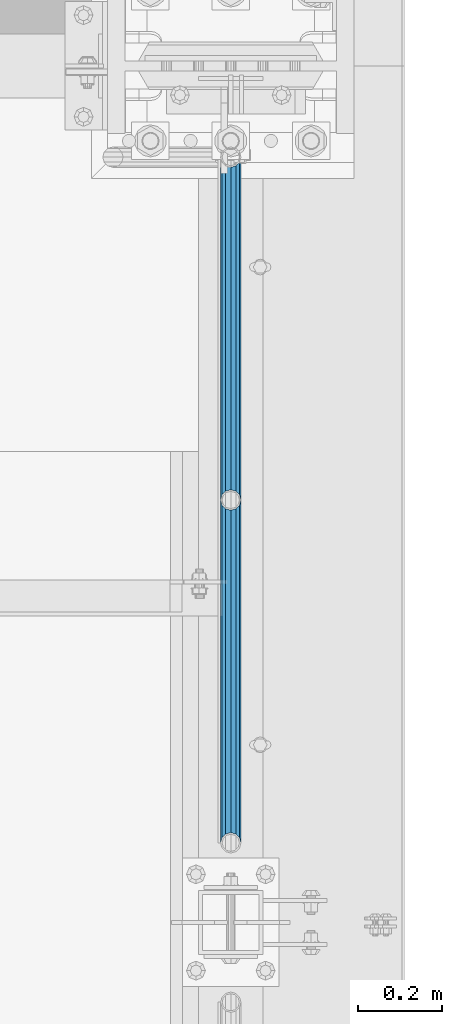
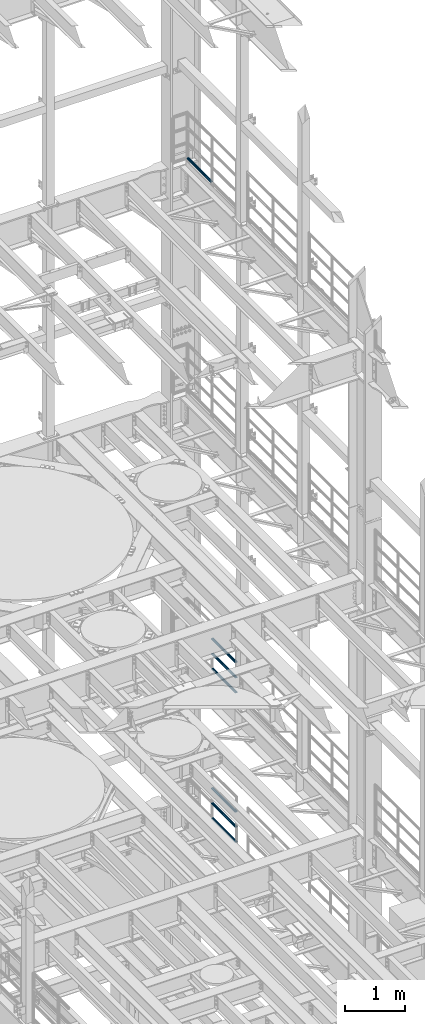
# One storey, part 1350 of 1876: 7 beams, 3 elements without a shape of their own.
"""IFC2X3 building model written with IfcOpenShell, lengths in millimetres."""

from ifc_helpers import new_model, si_unit, frame, origin_with_axes, place, context, subcontext, project, spatial, faceted_brep, material, type_object, element, aggregate, save


model = new_model("IFC2X3")

# Units and contexts
model_context = context("Model", 3, precision=1e-05, world=origin_with_axes())
body_context = subcontext(model_context, "Body", "Model", "MODEL_VIEW")
ifc_project = project(units=[si_unit("LENGTHUNIT", "METRE", prefix="MILLI"), si_unit("AREAUNIT", "SQUARE_METRE"), si_unit("VOLUMEUNIT", "CUBIC_METRE"), si_unit("MASSUNIT", "GRAM", prefix="KILO"), si_unit("TIMEUNIT", "SECOND"), si_unit("PLANEANGLEUNIT", "RADIAN"), si_unit("SOLIDANGLEUNIT", "STERADIAN"), si_unit("THERMODYNAMICTEMPERATUREUNIT", "DEGREE_CELSIUS"), si_unit("LUMINOUSINTENSITYUNIT", "LUMEN")], contexts=[model_context])

# Site, building, storey
site_placement = place(None, origin_with_axes())
site = spatial("IfcSite", under=ifc_project, at=site_placement, CompositionType="ELEMENT")
building_placement = place(site_placement, origin_with_axes())
building = spatial("IfcBuilding", under=site, at=building_placement, Name="Undefined", CompositionType="ELEMENT")
storey_placement = place(building_placement, origin_with_axes())
storey = spatial("IfcBuildingStorey", under=building, at=storey_placement, Name="Undefined", CompositionType="ELEMENT", Elevation=0.0)

# Assembly, beam
assembly_1_placement = place(storey_placement, origin_with_axes())
assembly_1 = element("IfcElementAssembly", 1, at=assembly_1_placement, inside=storey, Name="RAIL", AssemblyPlace="NOTDEFINED", PredefinedType="RIGID_FRAME")
ifc_material = material()
beam_type = type_object("IfcBeamType", Name="PIPE1-1/2SCH40", PredefinedType="NOTDEFINED")
beam_1_placement = place(assembly_1_placement, frame((7620.00000000002, 13499.7063, 18145.125), z_axis=(0.0, 0.0, 1.0), x_axis=(0.0, -1.0, 0.0)))
beam_1 = element("IfcBeam", 2, at=beam_1_placement, type_object=beam_type, material=ifc_material, Name="RAIL", ObjectType="PIPE1-1/2SCH40", context=body_context, shape_type="Brep", body=[
    faceted_brep([(792.499707006684, -12.0649999999996, 20.8971929933177), (792.499707006684, -12.0650000000314, 15.8661214311469), (792.006278568813, -10.2235000000001, 17.7076214311819), (789.266900000001, -9.09494701772928e-13, 20.4470000000001), (789.266900000001, -9.09494701772928e-13, 24.130000000001), (792.00627856883, 10.2235000000001, 17.7076214311819), (792.499707006684, 12.0649999999678, 15.8661214312124), (792.499707006684, 12.0649999999996, 20.8971929933177), (813.396900000002, 24.1300000000001, 0.0), (801.331900000001, 20.8971929933186, 12.0649999999987), (801.331900000001, 20.8971929933186, -12.0649999999987), (798.142328437896, 17.7076214311801, 10.2235000000001), (800.881707006714, 20.4470000000001, 0.0), (798.142328437896, 17.7076214311801, -10.2235000000001), (792.499707006684, 12.0649999999678, -15.8661214312124), (792.499707006684, 12.0649999999996, -20.8971929933177), (792.00627856883, 10.2235000000001, -17.7076214311819), (789.266900000001, 0.0, -20.4470000000001), (789.266900000001, 0.0, -24.130000000001), (792.499707006684, -12.0650000000314, -15.8661214311469), (792.499707006684, -12.0649999999996, -20.8971929933177), (792.006278568813, -10.2235000000001, -17.7076214311819), (813.396900000002, -24.1300000000319, 0.0), (801.331900000001, -20.8971929933186, -12.0649999999987), (801.331900000001, -20.8971929933186, 12.0649999999987), (798.142328437831, -17.7076214311801, -10.2235000000001), (800.881707006651, -20.4470000000001, 0.0), (798.142328437831, -17.7076214311801, 10.2235000000001), (12.0650000000064, -20.8971929933177, -12.0649999999987), (20.8971929933249, -12.0650000000005, -20.8971929933177), (0.0, 24.1299999999992, 0.0), (12.0650000000064, 20.8971929933177, -12.0649999999987), (12.0650000000064, 20.8971929933177, 12.0649999999987), (20.8971929933249, 12.0650000000005, 20.8971929933177), (24.1300000000064, 0.0, 24.130000000001), (20.8971929933249, 12.0650000000005, -20.8971929933177), (24.1300000000063, 0.0, -24.130000000001), (24.1300000000063, 0.0, -20.4470000000001), (20.8971929933249, -12.0650000000005, -15.8661214311796), (21.3906214311868, -10.2235000000001, -17.7076214311819), (21.3906214311868, 10.2235000000001, -17.7076214311819), (20.8971929933249, 12.0650000000005, -15.8661214311796), (15.2545715621445, 17.7076214311801, -10.2235000000001), (12.5151929933249, 20.4470000000001, 0.0), (15.2545715621445, 17.7076214311801, 10.2235000000001), (20.8971929933249, 12.0650000000005, 15.8661214311796), (21.3906214311868, 10.2235000000001, 17.7076214311819), (24.1300000000064, 0.0, 20.4470000000001), (21.3906214311868, -10.2235000000001, 17.7076214311819), (20.8971929933249, -12.0650000000005, 15.8661214311796), (20.8971929933249, -12.0650000000005, 20.8971929933177), (12.0650000000064, -20.8971929933177, 12.0649999999987), (0.0, -24.1299999999992, 0.0), (15.2545715621445, -17.7076214311801, 10.2235000000001), (12.5151929933249, -20.4470000000001, 0.0), (15.2545715621445, -17.7076214311801, -10.2235000000001)], [[[0, 1, 2, 3, 4]], [[4, 3, 5, 6, 7]], [[8, 9, 10]], [[7, 6, 11, 12, 13, 14, 15, 10, 9]], [[16, 17, 18, 15, 14]], [[19, 20, 18, 17, 21]], [[22, 23, 24]], [[24, 23, 20, 19, 25, 26, 27, 1, 0]], [[28, 29, 20, 23]], [[30, 31, 32]], [[33, 34, 4, 7]], [[32, 33, 7, 9]], [[30, 32, 9, 8]], [[31, 30, 8, 10]], [[35, 31, 10, 15]], [[36, 35, 15, 18]], [[29, 36, 18, 20]], [[37, 36, 29, 38, 39]], [[40, 41, 35, 36, 37]], [[32, 31, 35, 41, 42, 43, 44, 45, 33]], [[33, 45, 46, 47, 34]], [[34, 47, 48, 49, 50]], [[34, 50, 0, 4]], [[50, 51, 24, 0]], [[51, 52, 22, 24]], [[52, 28, 23, 22]], [[51, 28, 52]], [[50, 49, 53, 54, 55, 38, 29, 28, 51]], [[55, 54, 26, 25]], [[21, 39, 38, 55, 25, 19]], [[37, 39, 21, 17]], [[40, 37, 17, 16]], [[42, 41, 40, 16, 14, 13]], [[43, 42, 13, 12]], [[44, 43, 12, 11]], [[5, 46, 45, 44, 11, 6]], [[47, 46, 5, 3]], [[48, 47, 3, 2]], [[53, 49, 48, 2, 1, 27]], [[54, 53, 27, 26]]]),
])
aggregate(assembly_1, [beam_1])

# Assembly, beams
assembly_2_placement = place(storey_placement, origin_with_axes())
assembly_2 = element("IfcElementAssembly", 3, at=assembly_2_placement, inside=storey, Name="RAIL", AssemblyPlace="NOTDEFINED", PredefinedType="RIGID_FRAME")
beam_2_placement = place(assembly_2_placement, frame((7619.99999999997, 12686.3094, 8315.325), z_axis=(0.0, 0.0, 1.0), x_axis=(0.0, -1.0, 0.0)))
beam_2 = element("IfcBeam", 4, at=beam_2_placement, type_object=beam_type, material=ifc_material, Name="RAIL", ObjectType="PIPE1-1/2SCH40", context=body_context, shape_type="Brep", body=[
    faceted_brep([(792.499707006684, -12.0649999999996, 20.8971929933177), (792.499707006684, -12.0650000000314, 15.8661214311469), (792.006278568813, -10.2235000000001, 17.7076214311819), (789.266900000001, -9.09494701772928e-13, 20.4470000000001), (789.266900000001, -9.09494701772928e-13, 24.130000000001), (792.00627856883, 10.2235000000001, 17.7076214311819), (792.499707006684, 12.0649999999678, 15.8661214312124), (792.499707006684, 12.0649999999996, 20.8971929933177), (813.396900000002, 24.1300000000001, 0.0), (801.331900000001, 20.8971929933186, 12.0649999999987), (801.331900000001, 20.8971929933186, -12.0649999999987), (798.142328437896, 17.7076214311801, 10.2235000000001), (800.881707006714, 20.4470000000001, 0.0), (798.142328437896, 17.7076214311801, -10.2235000000001), (792.499707006684, 12.0649999999678, -15.8661214312124), (792.499707006684, 12.0649999999996, -20.8971929933177), (792.00627856883, 10.2235000000001, -17.7076214311819), (789.266900000001, 0.0, -20.4470000000001), (789.266900000001, 0.0, -24.130000000001), (792.499707006684, -12.0650000000314, -15.8661214311469), (792.499707006684, -12.0649999999996, -20.8971929933177), (792.006278568813, -10.2235000000001, -17.7076214311819), (813.396900000002, -24.1300000000319, 0.0), (801.331900000001, -20.8971929933186, -12.0649999999987), (801.331900000001, -20.8971929933186, 12.0649999999987), (798.142328437831, -17.7076214311801, -10.2235000000001), (800.881707006651, -20.4470000000001, 0.0), (798.142328437831, -17.7076214311801, 10.2235000000001), (12.0650000000064, -20.8971929933177, -12.0649999999987), (20.8971929933249, -12.0650000000005, -20.8971929933177), (0.0, 24.1299999999992, 0.0), (12.0650000000064, 20.8971929933177, -12.0649999999987), (12.0650000000064, 20.8971929933177, 12.0649999999987), (20.8971929933249, 12.0650000000005, 20.8971929933177), (24.1300000000064, 0.0, 24.130000000001), (20.8971929933249, 12.0650000000005, -20.8971929933177), (24.1300000000063, 0.0, -24.130000000001), (24.1300000000063, 0.0, -20.4470000000001), (20.8971929933249, -12.0650000000005, -15.8661214311796), (21.3906214311868, -10.2235000000001, -17.7076214311819), (21.3906214311868, 10.2235000000001, -17.7076214311819), (20.8971929933249, 12.0650000000005, -15.8661214311796), (15.2545715621445, 17.7076214311801, -10.2235000000001), (12.5151929933249, 20.4470000000001, 0.0), (15.2545715621445, 17.7076214311801, 10.2235000000001), (20.8971929933249, 12.0650000000005, 15.8661214311796), (21.3906214311868, 10.2235000000001, 17.7076214311819), (24.1300000000064, 0.0, 20.4470000000001), (21.3906214311868, -10.2235000000001, 17.7076214311819), (20.8971929933249, -12.0650000000005, 15.8661214311796), (20.8971929933249, -12.0650000000005, 20.8971929933177), (12.0650000000064, -20.8971929933177, 12.0649999999987), (0.0, -24.1299999999992, 0.0), (15.2545715621445, -17.7076214311801, 10.2235000000001), (12.5151929933249, -20.4470000000001, 0.0), (15.2545715621445, -17.7076214311801, -10.2235000000001)], [[[0, 1, 2, 3, 4]], [[4, 3, 5, 6, 7]], [[8, 9, 10]], [[7, 6, 11, 12, 13, 14, 15, 10, 9]], [[16, 17, 18, 15, 14]], [[19, 20, 18, 17, 21]], [[22, 23, 24]], [[24, 23, 20, 19, 25, 26, 27, 1, 0]], [[28, 29, 20, 23]], [[30, 31, 32]], [[33, 34, 4, 7]], [[32, 33, 7, 9]], [[30, 32, 9, 8]], [[31, 30, 8, 10]], [[35, 31, 10, 15]], [[36, 35, 15, 18]], [[29, 36, 18, 20]], [[37, 36, 29, 38, 39]], [[40, 41, 35, 36, 37]], [[32, 31, 35, 41, 42, 43, 44, 45, 33]], [[33, 45, 46, 47, 34]], [[34, 47, 48, 49, 50]], [[34, 50, 0, 4]], [[50, 51, 24, 0]], [[51, 52, 22, 24]], [[52, 28, 23, 22]], [[51, 28, 52]], [[50, 49, 53, 54, 55, 38, 29, 28, 51]], [[55, 54, 26, 25]], [[21, 39, 38, 55, 25, 19]], [[37, 39, 21, 17]], [[40, 37, 17, 16]], [[42, 41, 40, 16, 14, 13]], [[43, 42, 13, 12]], [[44, 43, 12, 11]], [[5, 46, 45, 44, 11, 6]], [[47, 46, 5, 3]], [[48, 47, 3, 2]], [[53, 49, 48, 2, 1, 27]], [[54, 53, 27, 26]]]),
])
beam_3_placement = place(assembly_2_placement, frame((7619.99999999997, 11872.9125, 8620.125), z_axis=(0.0, 0.0, -1.0), x_axis=(0.0, 1.0, 0.0)))
beam_3 = element("IfcBeam", 5, at=beam_3_placement, type_object=beam_type, material=ifc_material, Name="RAIL", ObjectType="PIPE1-1/2SCH40", context=body_context, shape_type="Brep", body=[
    faceted_brep([(0.0, 24.1299999999992, 0.0), (12.0650000000064, 20.8971929933177, -12.0649999999987), (12.0650000000064, 20.8971929933177, 12.0649999999987), (12.0650000000064, -20.8971929933177, 12.0649999999987), (12.0650000000064, -20.8971929933177, -12.0649999999987), (0.0, -24.1299999999992, 0.0), (20.8971929933249, -12.0650000000005, 20.8971929933177), (20.8971929933249, -12.0650000000005, 15.8661214311796), (15.2545715621445, -17.7076214311801, 10.2235000000001), (12.5151929933249, -20.4470000000001, 0.0), (15.2545715621445, -17.7076214311801, -10.2235000000001), (20.8971929933249, -12.0650000000005, -15.8661214311796), (20.8971929933249, -12.0650000000005, -20.8971929933177), (24.1300000000063, 0.0, -20.4470000000001), (24.1300000000063, 0.0, -24.130000000001), (21.3906214311868, -10.2235000000001, -17.7076214311819), (21.3906214311868, 10.2235000000001, -17.7076214311819), (20.8971929933249, 12.0650000000005, -15.8661214311796), (20.8971929933249, 12.0650000000005, -20.8971929933177), (15.2545715621445, 17.7076214311801, -10.2235000000001), (12.5151929933249, 20.4470000000001, 0.0), (15.2545715621445, 17.7076214311801, 10.2235000000001), (20.8971929933249, 12.0650000000005, 15.8661214311796), (20.8971929933249, 12.0650000000005, 20.8971929933177), (21.3906214311868, 10.2235000000001, 17.7076214311819), (24.1300000000064, 0.0, 20.4470000000001), (24.1300000000064, 0.0, 24.130000000001), (21.3906214311868, -10.2235000000001, 17.7076214311819), (813.396900000002, 24.1300000000001, 0.0), (801.331900000001, 20.8971929933186, -12.0649999999987), (792.499707006684, 12.0649999999996, -20.8971929933177), (813.396900000002, -24.1300000000319, 0.0), (801.331900000001, -20.8971929933186, -12.0649999999987), (801.331900000001, -20.8971929933186, 12.0649999999987), (792.499707006684, -12.0649999999996, 20.8971929933177), (792.499707006684, -12.0649999999996, -20.8971929933177), (789.266900000001, 0.0, -24.130000000001), (792.00627856883, 10.2235000000001, -17.7076214311819), (789.266900000001, 0.0, -20.4470000000001), (792.499707006684, 12.0649999999678, -15.8661214312124), (792.499707006684, -12.0650000000314, -15.8661214311469), (792.006278568813, -10.2235000000001, -17.7076214311819), (798.142328437831, -17.7076214311801, -10.2235000000001), (800.881707006651, -20.4470000000001, 0.0), (798.142328437831, -17.7076214311801, 10.2235000000001), (792.499707006684, -12.0650000000314, 15.8661214311469), (792.006278568813, -10.2235000000001, 17.7076214311819), (789.266900000001, -9.09494701772928e-13, 20.4470000000001), (789.266900000001, -9.09494701772928e-13, 24.130000000001), (792.499707006684, 12.0649999999996, 20.8971929933177), (801.331900000001, 20.8971929933186, 12.0649999999987), (792.499707006684, 12.0649999999678, 15.8661214312124), (798.142328437896, 17.7076214311801, 10.2235000000001), (800.881707006714, 20.4470000000001, 0.0), (798.142328437896, 17.7076214311801, -10.2235000000001), (792.00627856883, 10.2235000000001, 17.7076214311819)], [[[0, 1, 2]], [[3, 4, 5]], [[6, 7, 8, 9, 10, 11, 12, 4, 3]], [[13, 14, 12, 11, 15]], [[16, 17, 18, 14, 13]], [[2, 1, 18, 17, 19, 20, 21, 22, 23]], [[23, 22, 24, 25, 26]], [[26, 25, 27, 7, 6]], [[1, 0, 28, 29]], [[18, 1, 29, 30]], [[31, 32, 33]], [[6, 3, 33, 34]], [[3, 5, 31, 33]], [[5, 4, 32, 31]], [[4, 12, 35, 32]], [[12, 14, 36, 35]], [[14, 18, 30, 36]], [[37, 38, 36, 30, 39]], [[40, 35, 36, 38, 41]], [[33, 32, 35, 40, 42, 43, 44, 45, 34]], [[34, 45, 46, 47, 48]], [[26, 6, 34, 48]], [[2, 23, 49, 50]], [[23, 26, 48, 49]], [[0, 2, 50, 28]], [[28, 50, 29]], [[49, 51, 52, 53, 54, 39, 30, 29, 50]], [[48, 47, 55, 51, 49]], [[25, 24, 55, 47]], [[55, 24, 22, 21, 52, 51]], [[21, 20, 53, 52]], [[20, 19, 54, 53]], [[19, 17, 16, 37, 39, 54]], [[16, 13, 38, 37]], [[13, 15, 41, 38]], [[41, 15, 11, 10, 42, 40]], [[10, 9, 43, 42]], [[9, 8, 44, 43]], [[8, 7, 27, 46, 45, 44]], [[27, 25, 47, 46]]]),
])
beam_4_placement = place(assembly_2_placement, frame((7619.99999999997, 11872.9125, 8924.925), z_axis=(0.0, 0.0, -1.0), x_axis=(0.0, 1.0, 0.0)))
beam_4 = element("IfcBeam", 6, at=beam_4_placement, type_object=beam_type, material=ifc_material, Name="RAIL", ObjectType="PIPE1-1/2SCH40", context=body_context, shape_type="Brep", body=[
    faceted_brep([(0.0, 24.1299999999992, 0.0), (12.0650000000064, 20.8971929933177, -12.0649999999987), (12.0650000000064, 20.8971929933177, 12.0649999999987), (12.0650000000064, -20.8971929933177, 12.0649999999987), (12.0650000000064, -20.8971929933177, -12.0649999999987), (0.0, -24.1299999999992, 0.0), (20.8971929933249, -12.0650000000005, 20.8971929933177), (20.8971929933249, -12.0650000000005, 15.8661214311796), (15.2545715621445, -17.7076214311801, 10.2235000000001), (12.5151929933249, -20.4470000000001, 0.0), (15.2545715621445, -17.7076214311801, -10.2235000000001), (20.8971929933249, -12.0650000000005, -15.8661214311796), (20.8971929933249, -12.0650000000005, -20.8971929933177), (24.1300000000063, 0.0, -20.4470000000001), (24.1300000000063, 0.0, -24.130000000001), (21.3906214311868, -10.2235000000001, -17.7076214311819), (21.3906214311868, 10.2235000000001, -17.7076214311819), (20.8971929933249, 12.0650000000005, -15.8661214311796), (20.8971929933249, 12.0650000000005, -20.8971929933177), (15.2545715621445, 17.7076214311801, -10.2235000000001), (12.5151929933249, 20.4470000000001, 0.0), (15.2545715621445, 17.7076214311801, 10.2235000000001), (20.8971929933249, 12.0650000000005, 15.8661214311796), (20.8971929933249, 12.0650000000005, 20.8971929933177), (21.3906214311868, 10.2235000000001, 17.7076214311819), (24.1300000000064, 0.0, 20.4470000000001), (24.1300000000064, 0.0, 24.130000000001), (21.3906214311868, -10.2235000000001, 17.7076214311819), (813.396900000002, 24.1300000000001, 0.0), (801.331900000001, 20.8971929933186, -12.0649999999987), (792.499707006684, 12.0649999999996, -20.8971929933177), (813.396900000002, -24.1300000000319, 0.0), (801.331900000001, -20.8971929933186, -12.0649999999987), (801.331900000001, -20.8971929933186, 12.0649999999987), (792.499707006684, -12.0649999999996, 20.8971929933177), (792.499707006684, -12.0649999999996, -20.8971929933177), (789.266900000001, 0.0, -24.130000000001), (792.00627856883, 10.2235000000001, -17.7076214311819), (789.266900000001, 0.0, -20.4470000000001), (792.499707006684, 12.0649999999678, -15.8661214312124), (792.499707006684, -12.0650000000314, -15.8661214311469), (792.006278568813, -10.2235000000001, -17.7076214311819), (798.142328437831, -17.7076214311801, -10.2235000000001), (800.881707006651, -20.4470000000001, 0.0), (798.142328437831, -17.7076214311801, 10.2235000000001), (792.499707006684, -12.0650000000314, 15.8661214311469), (792.006278568813, -10.2235000000001, 17.7076214311819), (789.266900000001, -9.09494701772928e-13, 20.4470000000001), (789.266900000001, -9.09494701772928e-13, 24.130000000001), (792.499707006684, 12.0649999999996, 20.8971929933177), (801.331900000001, 20.8971929933186, 12.0649999999987), (792.499707006684, 12.0649999999678, 15.8661214312124), (798.142328437896, 17.7076214311801, 10.2235000000001), (800.881707006714, 20.4470000000001, 0.0), (798.142328437896, 17.7076214311801, -10.2235000000001), (792.00627856883, 10.2235000000001, 17.7076214311819)], [[[0, 1, 2]], [[3, 4, 5]], [[6, 7, 8, 9, 10, 11, 12, 4, 3]], [[13, 14, 12, 11, 15]], [[16, 17, 18, 14, 13]], [[2, 1, 18, 17, 19, 20, 21, 22, 23]], [[23, 22, 24, 25, 26]], [[26, 25, 27, 7, 6]], [[1, 0, 28, 29]], [[18, 1, 29, 30]], [[31, 32, 33]], [[6, 3, 33, 34]], [[3, 5, 31, 33]], [[5, 4, 32, 31]], [[4, 12, 35, 32]], [[12, 14, 36, 35]], [[14, 18, 30, 36]], [[37, 38, 36, 30, 39]], [[40, 35, 36, 38, 41]], [[33, 32, 35, 40, 42, 43, 44, 45, 34]], [[34, 45, 46, 47, 48]], [[26, 6, 34, 48]], [[2, 23, 49, 50]], [[23, 26, 48, 49]], [[0, 2, 50, 28]], [[28, 50, 29]], [[49, 51, 52, 53, 54, 39, 30, 29, 50]], [[48, 47, 55, 51, 49]], [[25, 24, 55, 47]], [[55, 24, 22, 21, 52, 51]], [[21, 20, 53, 52]], [[20, 19, 54, 53]], [[19, 17, 16, 37, 39, 54]], [[16, 13, 38, 37]], [[13, 15, 41, 38]], [[41, 15, 11, 10, 42, 40]], [[10, 9, 43, 42]], [[9, 8, 44, 43]], [[8, 7, 27, 46, 45, 44]], [[27, 25, 47, 46]]]),
])
aggregate(assembly_2, [beam_2, beam_3, beam_4])

assembly_3_placement = place(storey_placement, origin_with_axes())
assembly_3 = element("IfcElementAssembly", 7, at=assembly_3_placement, inside=storey, Name="RAIL", AssemblyPlace="NOTDEFINED", PredefinedType="RIGID_FRAME")
beam_5_placement = place(assembly_3_placement, frame((7619.99999999997, 12686.3094, 5292.725), z_axis=(0.0, 0.0, 1.0), x_axis=(0.0, -1.0, 0.0)))
beam_5 = element("IfcBeam", 8, at=beam_5_placement, type_object=beam_type, material=ifc_material, Name="RAIL", ObjectType="PIPE1-1/2SCH40", context=body_context, shape_type="Brep", body=[
    faceted_brep([(792.499707006684, -12.0649999999996, 20.8971929933177), (792.499707006684, -12.0650000000314, 15.8661214311469), (792.006278568813, -10.2235000000001, 17.7076214311819), (789.266900000001, -9.09494701772928e-13, 20.4470000000001), (789.266900000001, -9.09494701772928e-13, 24.130000000001), (792.00627856883, 10.2235000000001, 17.7076214311819), (792.499707006684, 12.0649999999678, 15.8661214312124), (792.499707006684, 12.0649999999996, 20.8971929933177), (813.396900000002, 24.1300000000001, 0.0), (801.331900000001, 20.8971929933186, 12.0649999999987), (801.331900000001, 20.8971929933186, -12.0649999999987), (798.142328437896, 17.7076214311801, 10.2235000000001), (800.881707006714, 20.4470000000001, 0.0), (798.142328437896, 17.7076214311801, -10.2235000000001), (792.499707006684, 12.0649999999678, -15.8661214312124), (792.499707006684, 12.0649999999996, -20.8971929933177), (792.00627856883, 10.2235000000001, -17.7076214311819), (789.266900000001, 0.0, -20.4470000000001), (789.266900000001, 0.0, -24.130000000001), (792.499707006684, -12.0650000000314, -15.8661214311469), (792.499707006684, -12.0649999999996, -20.8971929933177), (792.006278568813, -10.2235000000001, -17.7076214311819), (813.396900000002, -24.1300000000319, 0.0), (801.331900000001, -20.8971929933186, -12.0649999999987), (801.331900000001, -20.8971929933186, 12.0649999999987), (798.142328437831, -17.7076214311801, -10.2235000000001), (800.881707006651, -20.4470000000001, 0.0), (798.142328437831, -17.7076214311801, 10.2235000000001), (12.0650000000064, -20.8971929933177, -12.0649999999987), (20.8971929933249, -12.0650000000005, -20.8971929933177), (0.0, 24.1299999999992, 0.0), (12.0650000000064, 20.8971929933177, -12.0649999999987), (12.0650000000064, 20.8971929933177, 12.0649999999987), (20.8971929933249, 12.0650000000005, 20.8971929933177), (24.1300000000064, 0.0, 24.130000000001), (20.8971929933249, 12.0650000000005, -20.8971929933177), (24.1300000000063, 0.0, -24.130000000001), (24.1300000000063, 0.0, -20.4470000000001), (20.8971929933249, -12.0650000000005, -15.8661214311796), (21.3906214311868, -10.2235000000001, -17.7076214311819), (21.3906214311868, 10.2235000000001, -17.7076214311819), (20.8971929933249, 12.0650000000005, -15.8661214311796), (15.2545715621445, 17.7076214311801, -10.2235000000001), (12.5151929933249, 20.4470000000001, 0.0), (15.2545715621445, 17.7076214311801, 10.2235000000001), (20.8971929933249, 12.0650000000005, 15.8661214311796), (21.3906214311868, 10.2235000000001, 17.7076214311819), (24.1300000000064, 0.0, 20.4470000000001), (21.3906214311868, -10.2235000000001, 17.7076214311819), (20.8971929933249, -12.0650000000005, 15.8661214311796), (20.8971929933249, -12.0650000000005, 20.8971929933177), (12.0650000000064, -20.8971929933177, 12.0649999999987), (0.0, -24.1299999999992, 0.0), (15.2545715621445, -17.7076214311801, 10.2235000000001), (12.5151929933249, -20.4470000000001, 0.0), (15.2545715621445, -17.7076214311801, -10.2235000000001)], [[[0, 1, 2, 3, 4]], [[4, 3, 5, 6, 7]], [[8, 9, 10]], [[7, 6, 11, 12, 13, 14, 15, 10, 9]], [[16, 17, 18, 15, 14]], [[19, 20, 18, 17, 21]], [[22, 23, 24]], [[24, 23, 20, 19, 25, 26, 27, 1, 0]], [[28, 29, 20, 23]], [[30, 31, 32]], [[33, 34, 4, 7]], [[32, 33, 7, 9]], [[30, 32, 9, 8]], [[31, 30, 8, 10]], [[35, 31, 10, 15]], [[36, 35, 15, 18]], [[29, 36, 18, 20]], [[37, 36, 29, 38, 39]], [[40, 41, 35, 36, 37]], [[32, 31, 35, 41, 42, 43, 44, 45, 33]], [[33, 45, 46, 47, 34]], [[34, 47, 48, 49, 50]], [[34, 50, 0, 4]], [[50, 51, 24, 0]], [[51, 52, 22, 24]], [[52, 28, 23, 22]], [[51, 28, 52]], [[50, 49, 53, 54, 55, 38, 29, 28, 51]], [[55, 54, 26, 25]], [[21, 39, 38, 55, 25, 19]], [[37, 39, 21, 17]], [[40, 37, 17, 16]], [[42, 41, 40, 16, 14, 13]], [[43, 42, 13, 12]], [[44, 43, 12, 11]], [[5, 46, 45, 44, 11, 6]], [[47, 46, 5, 3]], [[48, 47, 3, 2]], [[53, 49, 48, 2, 1, 27]], [[54, 53, 27, 26]]]),
])
beam_6_placement = place(assembly_3_placement, frame((7619.99999999997, 11872.9125, 5597.525), z_axis=(0.0, 0.0, -1.0), x_axis=(0.0, 1.0, 0.0)))
beam_6 = element("IfcBeam", 9, at=beam_6_placement, type_object=beam_type, material=ifc_material, Name="RAIL", ObjectType="PIPE1-1/2SCH40", context=body_context, shape_type="Brep", body=[
    faceted_brep([(0.0, 24.1299999999992, 0.0), (12.0650000000064, 20.8971929933177, -12.0649999999987), (12.0650000000064, 20.8971929933177, 12.0649999999987), (12.0650000000064, -20.8971929933177, 12.0649999999987), (12.0650000000064, -20.8971929933177, -12.0649999999987), (0.0, -24.1299999999992, 0.0), (20.8971929933249, -12.0650000000005, 20.8971929933177), (20.8971929933249, -12.0650000000005, 15.8661214311796), (15.2545715621445, -17.7076214311801, 10.2235000000001), (12.5151929933249, -20.4470000000001, 0.0), (15.2545715621445, -17.7076214311801, -10.2235000000001), (20.8971929933249, -12.0650000000005, -15.8661214311796), (20.8971929933249, -12.0650000000005, -20.8971929933177), (24.1300000000063, 0.0, -20.4470000000001), (24.1300000000063, 0.0, -24.130000000001), (21.3906214311868, -10.2235000000001, -17.7076214311819), (21.3906214311868, 10.2235000000001, -17.7076214311819), (20.8971929933249, 12.0650000000005, -15.8661214311796), (20.8971929933249, 12.0650000000005, -20.8971929933177), (15.2545715621445, 17.7076214311801, -10.2235000000001), (12.5151929933249, 20.4470000000001, 0.0), (15.2545715621445, 17.7076214311801, 10.2235000000001), (20.8971929933249, 12.0650000000005, 15.8661214311796), (20.8971929933249, 12.0650000000005, 20.8971929933177), (21.3906214311868, 10.2235000000001, 17.7076214311819), (24.1300000000064, 0.0, 20.4470000000001), (24.1300000000064, 0.0, 24.130000000001), (21.3906214311868, -10.2235000000001, 17.7076214311819), (813.396900000002, 24.1300000000001, 0.0), (801.331900000001, 20.8971929933186, -12.0649999999987), (792.499707006684, 12.0649999999996, -20.8971929933177), (813.396900000002, -24.1300000000319, 0.0), (801.331900000001, -20.8971929933186, -12.0649999999987), (801.331900000001, -20.8971929933186, 12.0649999999987), (792.499707006684, -12.0649999999996, 20.8971929933177), (792.499707006684, -12.0649999999996, -20.8971929933177), (789.266900000001, 0.0, -24.130000000001), (792.00627856883, 10.2235000000001, -17.7076214311819), (789.266900000001, 0.0, -20.4470000000001), (792.499707006684, 12.0649999999678, -15.8661214312124), (792.499707006684, -12.0650000000314, -15.8661214311469), (792.006278568813, -10.2235000000001, -17.7076214311819), (798.142328437831, -17.7076214311801, -10.2235000000001), (800.881707006651, -20.4470000000001, 0.0), (798.142328437831, -17.7076214311801, 10.2235000000001), (792.499707006684, -12.0650000000314, 15.8661214311469), (792.006278568813, -10.2235000000001, 17.7076214311819), (789.266900000001, -9.09494701772928e-13, 20.4470000000001), (789.266900000001, -9.09494701772928e-13, 24.130000000001), (792.499707006684, 12.0649999999996, 20.8971929933177), (801.331900000001, 20.8971929933186, 12.0649999999987), (792.499707006684, 12.0649999999678, 15.8661214312124), (798.142328437896, 17.7076214311801, 10.2235000000001), (800.881707006714, 20.4470000000001, 0.0), (798.142328437896, 17.7076214311801, -10.2235000000001), (792.00627856883, 10.2235000000001, 17.7076214311819)], [[[0, 1, 2]], [[3, 4, 5]], [[6, 7, 8, 9, 10, 11, 12, 4, 3]], [[13, 14, 12, 11, 15]], [[16, 17, 18, 14, 13]], [[2, 1, 18, 17, 19, 20, 21, 22, 23]], [[23, 22, 24, 25, 26]], [[26, 25, 27, 7, 6]], [[1, 0, 28, 29]], [[18, 1, 29, 30]], [[31, 32, 33]], [[6, 3, 33, 34]], [[3, 5, 31, 33]], [[5, 4, 32, 31]], [[4, 12, 35, 32]], [[12, 14, 36, 35]], [[14, 18, 30, 36]], [[37, 38, 36, 30, 39]], [[40, 35, 36, 38, 41]], [[33, 32, 35, 40, 42, 43, 44, 45, 34]], [[34, 45, 46, 47, 48]], [[26, 6, 34, 48]], [[2, 23, 49, 50]], [[23, 26, 48, 49]], [[0, 2, 50, 28]], [[28, 50, 29]], [[49, 51, 52, 53, 54, 39, 30, 29, 50]], [[48, 47, 55, 51, 49]], [[25, 24, 55, 47]], [[55, 24, 22, 21, 52, 51]], [[21, 20, 53, 52]], [[20, 19, 54, 53]], [[19, 17, 16, 37, 39, 54]], [[16, 13, 38, 37]], [[13, 15, 41, 38]], [[41, 15, 11, 10, 42, 40]], [[10, 9, 43, 42]], [[9, 8, 44, 43]], [[8, 7, 27, 46, 45, 44]], [[27, 25, 47, 46]]]),
])
beam_7_placement = place(assembly_3_placement, frame((7619.99999999997, 11872.9125, 5902.325), z_axis=(0.0, 0.0, -1.0), x_axis=(0.0, 1.0, 0.0)))
beam_7 = element("IfcBeam", 10, at=beam_7_placement, type_object=beam_type, material=ifc_material, Name="RAIL", ObjectType="PIPE1-1/2SCH40", context=body_context, shape_type="Brep", body=[
    faceted_brep([(0.0, 24.1299999999992, 0.0), (12.0650000000064, 20.8971929933177, -12.0649999999987), (12.0650000000064, 20.8971929933177, 12.0649999999987), (12.0650000000064, -20.8971929933177, 12.0649999999987), (12.0650000000064, -20.8971929933177, -12.0649999999987), (0.0, -24.1299999999992, 0.0), (20.8971929933249, -12.0650000000005, 20.8971929933177), (20.8971929933249, -12.0650000000005, 15.8661214311796), (15.2545715621445, -17.7076214311801, 10.2235000000001), (12.5151929933249, -20.4470000000001, 0.0), (15.2545715621445, -17.7076214311801, -10.2235000000001), (20.8971929933249, -12.0650000000005, -15.8661214311796), (20.8971929933249, -12.0650000000005, -20.8971929933177), (24.1300000000063, 0.0, -20.4470000000001), (24.1300000000063, 0.0, -24.130000000001), (21.3906214311868, -10.2235000000001, -17.7076214311819), (21.3906214311868, 10.2235000000001, -17.7076214311819), (20.8971929933249, 12.0650000000005, -15.8661214311796), (20.8971929933249, 12.0650000000005, -20.8971929933177), (15.2545715621445, 17.7076214311801, -10.2235000000001), (12.5151929933249, 20.4470000000001, 0.0), (15.2545715621445, 17.7076214311801, 10.2235000000001), (20.8971929933249, 12.0650000000005, 15.8661214311796), (20.8971929933249, 12.0650000000005, 20.8971929933177), (21.3906214311868, 10.2235000000001, 17.7076214311819), (24.1300000000064, 0.0, 20.4470000000001), (24.1300000000064, 0.0, 24.130000000001), (21.3906214311868, -10.2235000000001, 17.7076214311819), (813.396900000002, 24.1300000000001, 0.0), (801.331900000001, 20.8971929933186, -12.0649999999987), (792.499707006684, 12.0649999999996, -20.8971929933177), (813.396900000002, -24.1300000000319, 0.0), (801.331900000001, -20.8971929933186, -12.0649999999987), (801.331900000001, -20.8971929933186, 12.0649999999987), (792.499707006684, -12.0649999999996, 20.8971929933177), (792.499707006684, -12.0649999999996, -20.8971929933177), (789.266900000001, 0.0, -24.130000000001), (792.00627856883, 10.2235000000001, -17.7076214311819), (789.266900000001, 0.0, -20.4470000000001), (792.499707006684, 12.0649999999678, -15.8661214312124), (792.499707006684, -12.0650000000314, -15.8661214311469), (792.006278568813, -10.2235000000001, -17.7076214311819), (798.142328437831, -17.7076214311801, -10.2235000000001), (800.881707006651, -20.4470000000001, 0.0), (798.142328437831, -17.7076214311801, 10.2235000000001), (792.499707006684, -12.0650000000314, 15.8661214311469), (792.006278568813, -10.2235000000001, 17.7076214311819), (789.266900000001, -9.09494701772928e-13, 20.4470000000001), (789.266900000001, -9.09494701772928e-13, 24.130000000001), (792.499707006684, 12.0649999999996, 20.8971929933177), (801.331900000001, 20.8971929933186, 12.0649999999987), (792.499707006684, 12.0649999999678, 15.8661214312124), (798.142328437896, 17.7076214311801, 10.2235000000001), (800.881707006714, 20.4470000000001, 0.0), (798.142328437896, 17.7076214311801, -10.2235000000001), (792.00627856883, 10.2235000000001, 17.7076214311819)], [[[0, 1, 2]], [[3, 4, 5]], [[6, 7, 8, 9, 10, 11, 12, 4, 3]], [[13, 14, 12, 11, 15]], [[16, 17, 18, 14, 13]], [[2, 1, 18, 17, 19, 20, 21, 22, 23]], [[23, 22, 24, 25, 26]], [[26, 25, 27, 7, 6]], [[1, 0, 28, 29]], [[18, 1, 29, 30]], [[31, 32, 33]], [[6, 3, 33, 34]], [[3, 5, 31, 33]], [[5, 4, 32, 31]], [[4, 12, 35, 32]], [[12, 14, 36, 35]], [[14, 18, 30, 36]], [[37, 38, 36, 30, 39]], [[40, 35, 36, 38, 41]], [[33, 32, 35, 40, 42, 43, 44, 45, 34]], [[34, 45, 46, 47, 48]], [[26, 6, 34, 48]], [[2, 23, 49, 50]], [[23, 26, 48, 49]], [[0, 2, 50, 28]], [[28, 50, 29]], [[49, 51, 52, 53, 54, 39, 30, 29, 50]], [[48, 47, 55, 51, 49]], [[25, 24, 55, 47]], [[55, 24, 22, 21, 52, 51]], [[21, 20, 53, 52]], [[20, 19, 54, 53]], [[19, 17, 16, 37, 39, 54]], [[16, 13, 38, 37]], [[13, 15, 41, 38]], [[41, 15, 11, 10, 42, 40]], [[10, 9, 43, 42]], [[9, 8, 44, 43]], [[8, 7, 27, 46, 45, 44]], [[27, 25, 47, 46]]]),
])
aggregate(assembly_3, [beam_5, beam_6, beam_7])

save(model, "model.ifc")
